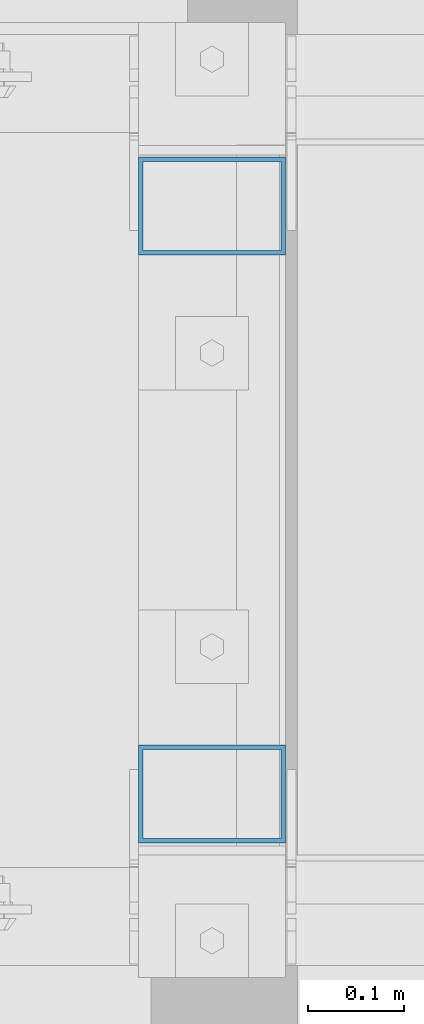
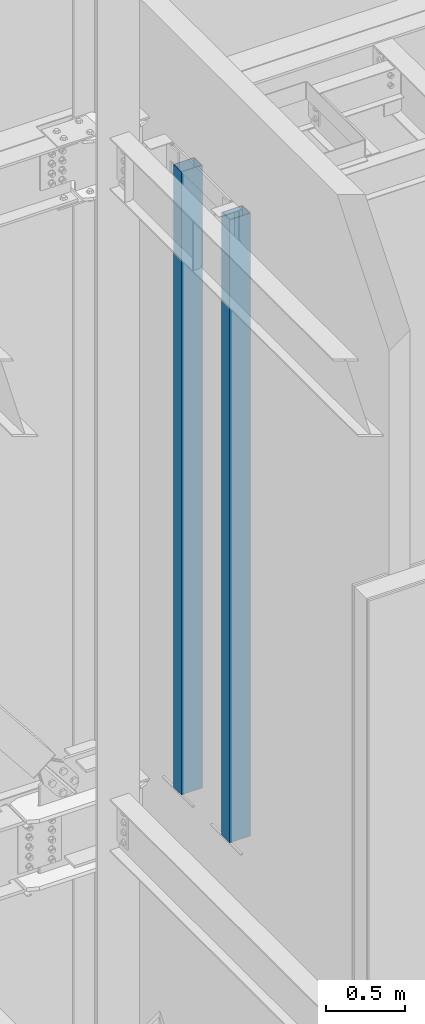
# One storey, part 377 of 1179: 2 columns, 2 elements without a shape of their own.
"""IFC2X3 building model written with IfcOpenShell, lengths in millimetres."""

from ifc_helpers import new_model, si_unit, frame, origin_with_axes, place, context, subcontext, project, spatial, faceted_brep, material, type_object, element, aggregate, save


model = new_model("IFC2X3")

# Units and contexts
model_context = context("Model", 3, precision=1e-05, world=origin_with_axes())
body_context = subcontext(model_context, "Body", "Model", "MODEL_VIEW")
ifc_project = project(units=[si_unit("LENGTHUNIT", "METRE", prefix="MILLI"), si_unit("AREAUNIT", "SQUARE_METRE"), si_unit("VOLUMEUNIT", "CUBIC_METRE"), si_unit("MASSUNIT", "GRAM", prefix="KILO"), si_unit("TIMEUNIT", "SECOND"), si_unit("PLANEANGLEUNIT", "RADIAN"), si_unit("SOLIDANGLEUNIT", "STERADIAN"), si_unit("THERMODYNAMICTEMPERATUREUNIT", "DEGREE_CELSIUS"), si_unit("LUMINOUSINTENSITYUNIT", "LUMEN")], contexts=[model_context])

# Site, building, storey
site_placement = place(None, origin_with_axes())
site = spatial("IfcSite", under=ifc_project, at=site_placement, CompositionType="ELEMENT")
building_placement = place(site_placement, origin_with_axes())
building = spatial("IfcBuilding", under=site, at=building_placement, Name="Undefined", CompositionType="ELEMENT")
storey_placement = place(building_placement, origin_with_axes())
storey = spatial("IfcBuildingStorey", under=building, at=storey_placement, Name="Undefined", CompositionType="ELEMENT", Elevation=0.0)

# Assembly, column
assembly_1_placement = place(storey_placement, origin_with_axes())
assembly_1 = element("IfcElementAssembly", 1, at=assembly_1_placement, inside=storey, Name="COLUMN", AssemblyPlace="NOTDEFINED", PredefinedType="RIGID_FRAME")
ifc_material = material()
column_type = type_object("IfcColumnType", Name="HSS6X4X3/16", PredefinedType="NOTDEFINED")
column_1_placement = place(assembly_1_placement, frame((16776.7, 40106.6, 8159.75), z_axis=(-1.0, 0.0, 0.0), x_axis=(0.0, 0.0, 1.0)))
column_1 = element("IfcColumn", 2, at=column_1_placement, type_object=column_type, material=ifc_material, Name="COLUMN", ObjectType="HSS6X4X3/16", context=body_context, shape_type="Brep", body=[
    faceted_brep([(0.0, 46.0374999999985, -71.4375), (0.0, -46.0374999999985, -71.4375), (4806.95, -46.0374999999985, -71.4375), (4806.95, 46.0374999999985, -71.4375), (0.0, -46.0374999999985, 71.4375), (4806.95, -46.0374999999985, 71.4375), (0.0, 46.0374999999985, 71.4375), (4806.95, 46.0374999999985, 71.4375), (0.0, 50.8000000000029, -76.1999999999998), (0.0, 50.8000000000029, 76.1999999999998), (4806.95, 50.8000000000029, 76.2000000000007), (4806.95, 50.8000000000029, -76.2000000000007), (0.0, -50.8000000000029, 76.2000000000007), (4806.95, -50.8000000000029, 76.2000000000007), (0.0, -50.8000000000029, -76.1999999999998), (4806.95, -50.8000000000029, -76.2000000000007)], [[[0, 1, 2, 3]], [[1, 4, 5, 2]], [[4, 6, 7, 5]], [[6, 0, 3, 7]], [[8, 9, 10, 11]], [[9, 12, 13, 10]], [[12, 14, 15, 13]], [[14, 8, 11, 15]], [[13, 15, 11, 10], [5, 7, 3, 2]], [[14, 12, 9, 8], [6, 4, 1, 0]]]),
])
aggregate(assembly_1, [column_1])

assembly_2_placement = place(storey_placement, origin_with_axes())
assembly_2 = element("IfcElementAssembly", 3, at=assembly_2_placement, inside=storey, Name="COLUMN", AssemblyPlace="NOTDEFINED", PredefinedType="RIGID_FRAME")
column_2_placement = place(assembly_2_placement, frame((16776.7, 40716.2, 8159.75), z_axis=(-1.0, 0.0, 0.0), x_axis=(0.0, 0.0, 1.0)))
column_2 = element("IfcColumn", 4, at=column_2_placement, type_object=column_type, material=ifc_material, Name="COLUMN", ObjectType="HSS6X4X3/16", context=body_context, shape_type="Brep", body=[
    faceted_brep([(0.0, 46.0374999999985, -71.4375), (0.0, -46.0374999999985, -71.4375), (4806.95, -46.0374999999985, -71.4375), (4806.95, 46.0374999999985, -71.4375), (0.0, -46.0374999999985, 71.4375), (4806.95, -46.0374999999985, 71.4375), (0.0, 46.0374999999985, 71.4375), (4806.95, 46.0374999999985, 71.4375), (0.0, 50.8000000000029, -76.1999999999998), (0.0, 50.8000000000029, 76.1999999999998), (4806.95, 50.8000000000029, 76.2000000000007), (4806.95, 50.8000000000029, -76.2000000000007), (0.0, -50.8000000000029, 76.2000000000007), (4806.95, -50.8000000000029, 76.2000000000007), (0.0, -50.8000000000029, -76.1999999999998), (4806.95, -50.8000000000029, -76.2000000000007)], [[[0, 1, 2, 3]], [[1, 4, 5, 2]], [[4, 6, 7, 5]], [[6, 0, 3, 7]], [[8, 9, 10, 11]], [[9, 12, 13, 10]], [[12, 14, 15, 13]], [[14, 8, 11, 15]], [[13, 15, 11, 10], [5, 7, 3, 2]], [[14, 12, 9, 8], [6, 4, 1, 0]]]),
])
aggregate(assembly_2, [column_2])

save(model, "model.ifc")
